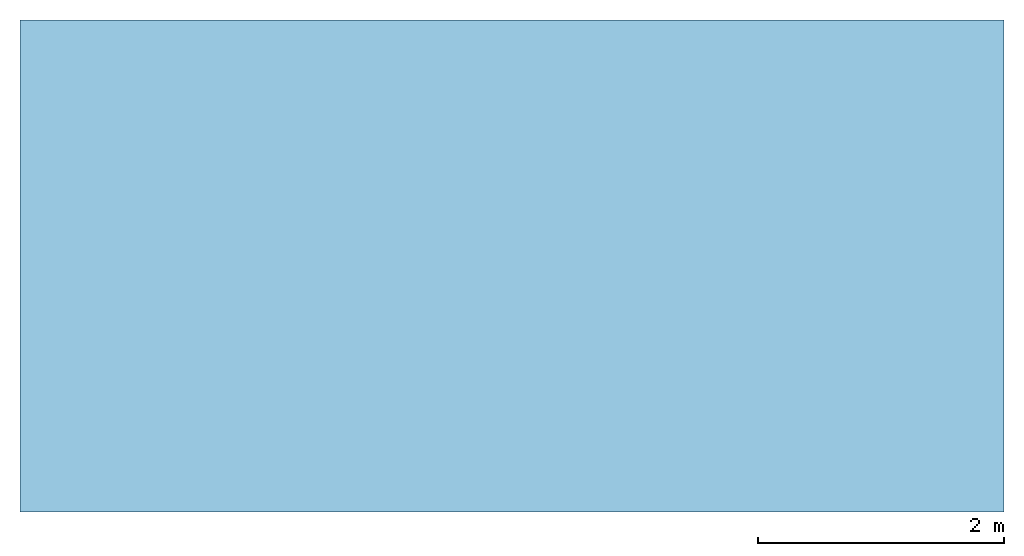
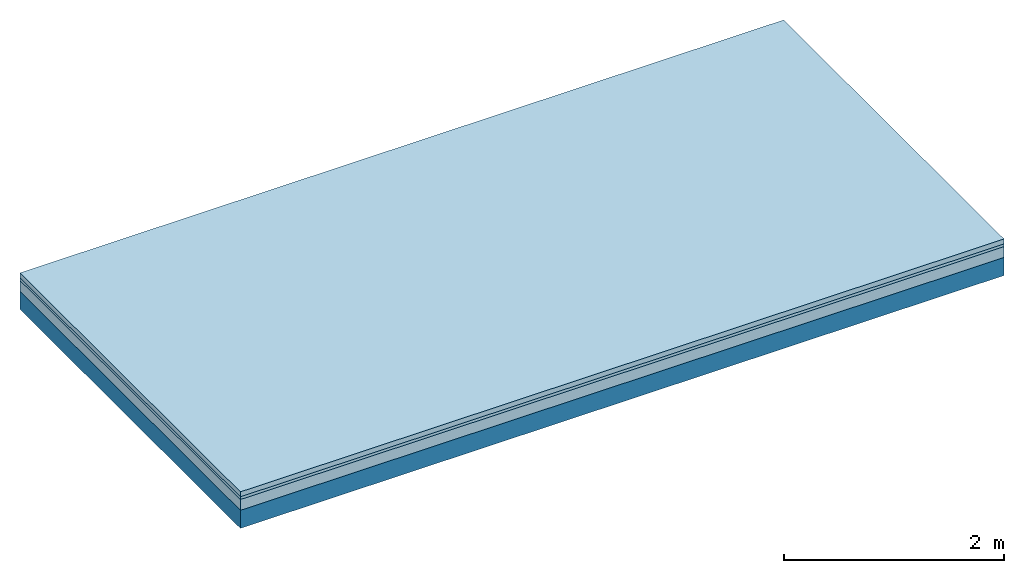
# One storey: 3 plates, 1 member, 1 element without a shape of its own.
"""IFC4 building model written with IfcOpenShell, lengths in metres."""

from ifc_helpers import new_model, si_unit, derived_unit, direction, frame, frame_2d, origin, origin_with_axes, place, context, project, spatial, rectangle, extrude, material, layer, layer_set, type_object, element, aggregate, save


model = new_model("IFC4")

# Units and contexts
plan_context = context("Plan", 3, precision=1e-05, world=origin(), true_north=direction((0.0, 1.0)))
model_context = context("Model", 3, precision=1e-05, world=origin(), true_north=direction((0.0, 1.0)))
ifc_project = project(units=[si_unit("LENGTHUNIT", "METRE"), derived_unit("SOUNDPRESSUREUNIT", [(si_unit("PRESSUREUNIT", "PASCAL", prefix="MICRO"), 0)]), si_unit("ENERGYUNIT", "JOULE", prefix="MEGA"), si_unit("MASSUNIT", "GRAM", prefix="KILO"), derived_unit("THERMALTRANSMITTANCEUNIT", [(si_unit("POWERUNIT", "WATT"), 1), (si_unit("AREAUNIT", "SQUARE_METRE"), -1), (si_unit("THERMODYNAMICTEMPERATUREUNIT", "KELVIN"), -1)]), derived_unit("AREADENSITYUNIT", [(si_unit("MASSUNIT", "GRAM", prefix="KILO"), 1), (si_unit("AREAUNIT", "SQUARE_METRE"), -1)]), derived_unit("USERDEFINED", [(si_unit("ENERGYUNIT", "JOULE", prefix="MEGA"), 1), (si_unit("AREAUNIT", "SQUARE_METRE"), -1)])], contexts=[plan_context, model_context])

# Site, building, storey
site = spatial("IfcSite", under=ifc_project)
building_placement = place(None, origin())
building = spatial("IfcBuilding", under=site, at=building_placement)
storey_placement = place(building_placement, origin())
storey = spatial("IfcBuildingStorey", under=building, at=storey_placement)

# Slab, member, plates
ifc_material_1 = material(Category="04.005")
ifc_layer_1 = layer(ifc_material_1, 0.055, Name="On-material")
ifc_material_2 = material()
ifc_layer_2 = layer(ifc_material_2, 0.03, Name="Impact sound insulation")
ifc_material_3 = material(Category="03.011")
ifc_layer_3 = layer(ifc_material_3, 0.12, Name="on Supporting structure")
ifc_layer_4 = layer(None, 0.2, Name="Supporting structure")
ifc_layer_set = layer_set([ifc_layer_1, ifc_layer_2, ifc_layer_3, ifc_layer_4])
slab_type = type_object("IfcSlabType", Name="A1100", PredefinedType="NOTDEFINED", material=ifc_layer_set)
slab_placement = place(None, frame((0.0, 0.0, 0.0), z_axis=(0.0, 0.0, -1.0), x_axis=(1.0, 0.0, 0.0)))
slab = element("IfcSlab", 1, at=slab_placement, inside=storey, type_object=slab_type, material=ifc_layer_set, Name="Slab #1")
ifc_material_4 = material()
member_placement = place(slab_placement, origin())
member = element("IfcMember", 2, at=member_placement, material=ifc_material_4, Name="Supporting structure", context=plan_context, shape_type="SweptSolid", body=[
    extrude(rectangle(XDim=1.0, YDim=0.2, at=frame_2d((0.5, 0.1), x_axis=(1.0, 0.0))), frame((0.0, 4.0, 0.205), z_axis=(0.0, -1.0, 0.0), x_axis=(1.0, 0.0, 0.0)), (0.0, 0.0, 1.0), 4.0),
    extrude(rectangle(XDim=1.0, YDim=0.2, at=frame_2d((0.5, 0.1), x_axis=(1.0, 0.0))), frame((1.0, 4.0, 0.205), z_axis=(0.0, -1.0, 0.0), x_axis=(1.0, 0.0, 0.0)), (0.0, 0.0, 1.0), 4.0),
    extrude(rectangle(XDim=1.0, YDim=0.2, at=frame_2d((0.5, 0.1), x_axis=(1.0, 0.0))), frame((2.0, 4.0, 0.205), z_axis=(0.0, -1.0, 0.0), x_axis=(1.0, 0.0, 0.0)), (0.0, 0.0, 1.0), 4.0),
    extrude(rectangle(XDim=1.0, YDim=0.2, at=frame_2d((0.5, 0.1), x_axis=(1.0, 0.0))), frame((3.0, 4.0, 0.205), z_axis=(0.0, -1.0, 0.0), x_axis=(1.0, 0.0, 0.0)), (0.0, 0.0, 1.0), 4.0),
    extrude(rectangle(XDim=1.0, YDim=0.2, at=frame_2d((0.5, 0.1), x_axis=(1.0, 0.0))), frame((4.0, 4.0, 0.205), z_axis=(0.0, -1.0, 0.0), x_axis=(1.0, 0.0, 0.0)), (0.0, 0.0, 1.0), 4.0),
    extrude(rectangle(XDim=1.0, YDim=0.2, at=frame_2d((0.5, 0.1), x_axis=(1.0, 0.0))), frame((5.0, 4.0, 0.205), z_axis=(0.0, -1.0, 0.0), x_axis=(1.0, 0.0, 0.0)), (0.0, 0.0, 1.0), 4.0),
    extrude(rectangle(XDim=1.0, YDim=0.2, at=frame_2d((0.5, 0.1), x_axis=(1.0, 0.0))), frame((6.0, 4.0, 0.205), z_axis=(0.0, -1.0, 0.0), x_axis=(1.0, 0.0, 0.0)), (0.0, 0.0, 1.0), 4.0),
    extrude(rectangle(XDim=1.0, YDim=0.2, at=frame_2d((0.5, 0.1), x_axis=(1.0, 0.0))), frame((7.0, 4.0, 0.205), z_axis=(0.0, -1.0, 0.0), x_axis=(1.0, 0.0, 0.0)), (0.0, 0.0, 1.0), 4.0),
])
plate_1_placement = place(slab_placement, origin())
plate_1 = element("IfcPlate", 3, at=plate_1_placement, material=ifc_material_1, Name="On-material", context=plan_context, shape_type="SweptSolid", body=[
    extrude(rectangle(XDim=8.0, YDim=4.0, at=frame_2d((4.0, 2.0), x_axis=(1.0, 0.0))), origin_with_axes(), (0.0, 0.0, 1.0), 0.055),
])
plate_2_placement = place(slab_placement, origin())
plate_2 = element("IfcPlate", 4, at=plate_2_placement, material=ifc_material_2, Name="Impact sound insulation", context=plan_context, shape_type="SweptSolid", body=[
    extrude(rectangle(XDim=8.0, YDim=4.0, at=frame_2d((4.0, 2.0), x_axis=(1.0, 0.0))), frame((0.0, 0.0, 0.055), z_axis=(0.0, 0.0, 1.0), x_axis=(1.0, 0.0, 0.0)), (0.0, 0.0, 1.0), 0.03),
])
plate_3_placement = place(slab_placement, origin())
plate_3 = element("IfcPlate", 5, at=plate_3_placement, material=ifc_material_3, Name="on Supporting structure", context=plan_context, shape_type="SweptSolid", body=[
    extrude(rectangle(XDim=8.0, YDim=4.0, at=frame_2d((4.0, 2.0), x_axis=(1.0, 0.0))), frame((0.0, 0.0, 0.085), z_axis=(0.0, 0.0, 1.0), x_axis=(1.0, 0.0, 0.0)), (0.0, 0.0, 1.0), 0.12),
])
aggregate(slab, [plate_1, plate_2, plate_3, member])

save(model, "model.ifc")
